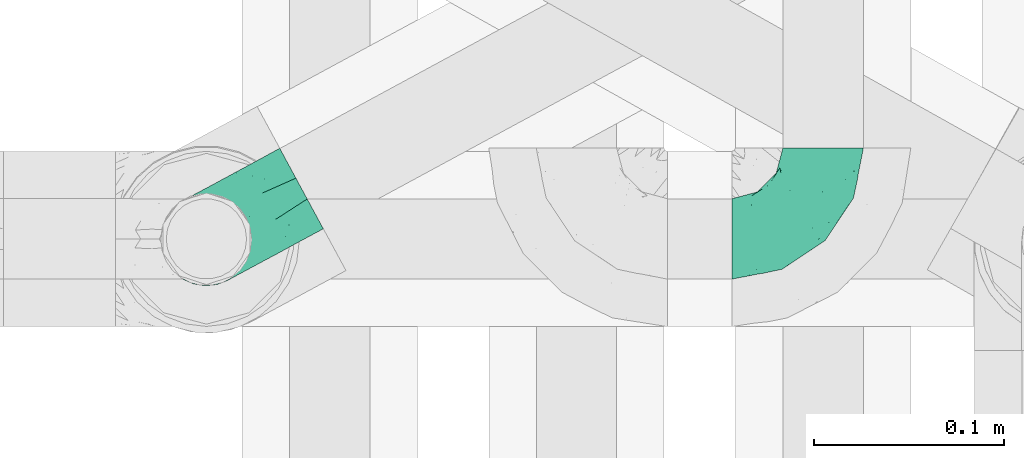
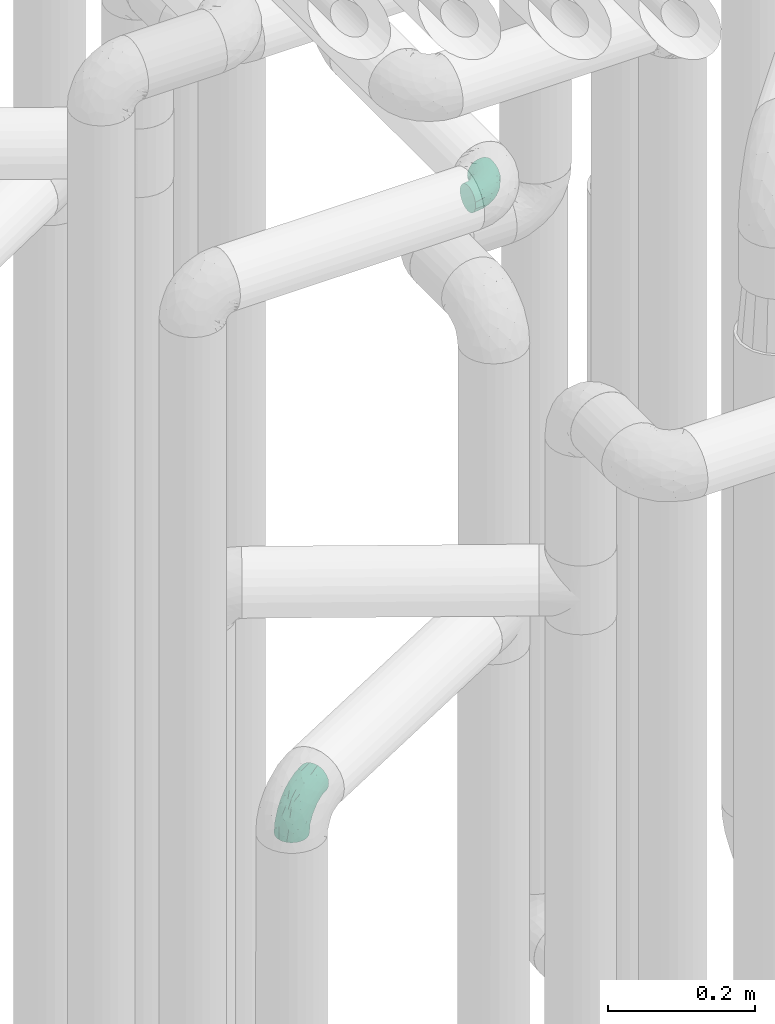
# One storey, part 793 of 827: 2 flow fittings.
"""IFC2X3 building model written with IfcOpenShell, lengths in millimetres."""

from ifc_helpers import new_model, entity, si_unit, converted_unit, derived_unit, direction, frame, origin, place, context, subcontext, project, spatial, faceted_brep, source, transform, mapped, material, type_object, type_shapes, element, save


model = new_model("IFC2X3")

# Units and contexts
model_context = context("Model", 3, precision=0.01, world=origin(), true_north=direction((6.12303176911189e-17, 1.0)))
body_context = subcontext(model_context, "Body", "Model", "MODEL_VIEW")
ifc_project = project(units=[si_unit("LENGTHUNIT", "METRE", prefix="MILLI"), si_unit("AREAUNIT", "SQUARE_METRE"), si_unit("VOLUMEUNIT", "CUBIC_METRE"), converted_unit("PLANEANGLEUNIT", "DEGREE", entity("IfcRatioMeasure", 0.0174532925199433), si_unit("PLANEANGLEUNIT", "RADIAN"), dimensions=[0, 0, 0, 0, 0, 0, 0]), si_unit("MASSUNIT", "GRAM", prefix="KILO"), derived_unit("MASSDENSITYUNIT", [(si_unit("MASSUNIT", "GRAM", prefix="KILO"), 1), (si_unit("LENGTHUNIT", "METRE"), -3)]), derived_unit("MOMENTOFINERTIAUNIT", [(si_unit("LENGTHUNIT", "METRE"), 4)]), si_unit("TIMEUNIT", "SECOND"), si_unit("FREQUENCYUNIT", "HERTZ"), si_unit("THERMODYNAMICTEMPERATUREUNIT", "DEGREE_CELSIUS"), derived_unit("THERMALTRANSMITTANCEUNIT", [(si_unit("MASSUNIT", "GRAM", prefix="KILO"), 1), (si_unit("THERMODYNAMICTEMPERATUREUNIT", "KELVIN"), -1), (si_unit("TIMEUNIT", "SECOND"), -3)]), derived_unit("VOLUMETRICFLOWRATEUNIT", [(si_unit("LENGTHUNIT", "METRE"), 3), (si_unit("TIMEUNIT", "SECOND"), -1)]), derived_unit("MASSFLOWRATEUNIT", [(si_unit("MASSUNIT", "GRAM", prefix="KILO"), 1), (si_unit("TIMEUNIT", "SECOND"), -1)]), derived_unit("ROTATIONALFREQUENCYUNIT", [(si_unit("TIMEUNIT", "SECOND"), -1)]), si_unit("ELECTRICCURRENTUNIT", "AMPERE"), si_unit("ELECTRICVOLTAGEUNIT", "VOLT"), si_unit("POWERUNIT", "WATT"), si_unit("FORCEUNIT", "NEWTON", prefix="KILO"), si_unit("ILLUMINANCEUNIT", "LUX"), si_unit("LUMINOUSFLUXUNIT", "LUMEN"), si_unit("LUMINOUSINTENSITYUNIT", "CANDELA"), derived_unit("USERDEFINED", [(si_unit("MASSUNIT", "GRAM", prefix="KILO"), -1), (si_unit("LENGTHUNIT", "METRE"), -2), (si_unit("TIMEUNIT", "SECOND"), 3), (si_unit("LUMINOUSFLUXUNIT", "LUMEN"), 1)]), derived_unit("LINEARVELOCITYUNIT", [(si_unit("LENGTHUNIT", "METRE"), 1), (si_unit("TIMEUNIT", "SECOND"), -1)]), si_unit("PRESSUREUNIT", "PASCAL"), derived_unit("USERDEFINED", [(si_unit("LENGTHUNIT", "METRE"), -2), (si_unit("MASSUNIT", "GRAM", prefix="KILO"), 1), (si_unit("TIMEUNIT", "SECOND"), -2)]), derived_unit("LINEARFORCEUNIT", [(si_unit("MASSUNIT", "GRAM", prefix="KILO"), 1), (si_unit("LENGTHUNIT", "METRE"), 1), (si_unit("TIMEUNIT", "SECOND"), -2), (si_unit("LENGTHUNIT", "METRE"), -1)]), derived_unit("PLANARFORCEUNIT", [(si_unit("MASSUNIT", "GRAM", prefix="KILO"), 1), (si_unit("LENGTHUNIT", "METRE"), 1), (si_unit("TIMEUNIT", "SECOND"), -2), (si_unit("LENGTHUNIT", "METRE"), -2)])], contexts=[model_context])

# Site, building, storey
site_placement = place(None, origin())
site = spatial("IfcSite", under=ifc_project, at=site_placement, CompositionType="ELEMENT")
building_placement = place(site_placement, origin())
building = spatial("IfcBuilding", under=site, at=building_placement, CompositionType="ELEMENT")
storey_placement = place(building_placement, frame((0.0, 0.0, 28200.0)))
storey = spatial("IfcBuildingStorey", under=building, at=storey_placement, Name="08", CompositionType="ELEMENT", Elevation=28200.0)

# Flow fittings
ifc_material = material()
pipe_fitting_type_1 = type_object("IfcPipeFittingType", Name="ADSK_1", PredefinedType="NOTDEFINED", material=ifc_material)
shared_shape_1 = source(origin(), body_context, "Body", "Brep", [
    faceted_brep([(-48.0, 10.6, -18.36), (-48.0, 5.49, -20.48), (-48.0, 0.0, -21.2), (-48.0, -5.49, -20.48), (-48.0, -10.6, -18.36), (-48.0, -14.99, -14.99), (-48.0, -18.36, -10.6), (-48.0, -20.48, -5.49), (-48.0, -21.2, 0.0), (-48.0, -20.48, 5.49), (-48.0, -18.36, 10.6), (-48.0, -14.99, 14.99), (-48.0, -10.6, 18.36), (-48.0, -5.49, 20.48), (-48.0, 0.0, 21.2), (-48.0, 5.49, 20.48), (-48.0, 10.6, 18.36), (-48.0, 14.99, 14.99), (-48.0, 18.36, 10.6), (-48.0, 20.48, 5.49), (-48.0, 21.2, 0.0), (-48.0, 20.48, -5.49), (-48.0, 18.36, -10.6), (-48.0, 14.99, -14.99), (0.0, 48.0, -21.2), (-5.49, 48.0, -20.48), (-10.6, 48.0, -18.36), (-14.99, 48.0, -14.99), (-18.36, 48.0, -10.6), (-20.48, 48.0, -5.49), (-21.2, 48.0, 0.0), (-20.48, 48.0, 5.49), (-18.36, 48.0, 10.6), (-14.99, 48.0, 14.99), (-10.6, 48.0, 18.36), (-5.49, 48.0, 20.48), (0.0, 48.0, 21.2), (5.48, 48.0, 20.48), (10.6, 48.0, 18.36), (14.99, 48.0, 14.99), (18.36, 48.0, 10.6), (20.48, 48.0, 5.49), (21.2, 48.0, 0.0), (20.48, 48.0, -5.49), (18.36, 48.0, -10.6), (14.99, 48.0, -14.99), (10.6, 48.0, -18.36), (5.48, 48.0, -20.48), (-35.26, -16.22, 12.01), (-34.76, -18.57, 0.0), (-20.87, -12.37, 10.9), (-31.49, -11.78, 15.9), (-37.01, -2.58, 20.86), (-33.89, 3.62, 21.15), (-31.81, -18.14, 6.76), (-5.78, 5.78, 17.67), (-19.42, -4.1, 17.86), (-9.6, -3.39, 13.73), (-35.45, -7.73, 19.13), (11.78, 31.49, 15.9), (-5.94, -5.46, 6.95), (-18.45, -13.78, 5.46), (-10.29, -8.43, 0.0), (-24.6, 0.55, 20.62), (-37.28, 17.94, 13.81), (-33.38, 22.85, 9.59), (-41.47, 20.06, 8.75), (-29.52, 20.45, 15.16), (-15.05, 10.79, 21.13), (-7.08, 16.98, 20.93), (-8.39, 23.51, 21.15), (-40.87, 13.03, 17.26), (-8.06, 41.27, 19.83), (-3.22, 35.97, 21.14), (8.53, 19.66, 14.74), (4.1, 19.42, 17.86), (-37.73, 22.66, 4.78), (-37.07, 8.58, 19.98), (-13.0, 5.43, 19.97), (-3.79, 13.93, 19.7), (3.02, 8.7, 13.43), (-2.27, -0.05, 10.65), (6.22, 7.0, 7.09), (-22.25, 34.61, 9.45), (18.14, 31.81, 6.76), (16.22, 35.26, 12.01), (12.37, 20.87, 10.9), (7.73, 35.45, 19.13), (-21.52, -15.93, 0.0), (2.58, 37.01, 20.86), (18.56, 34.76, 0.0), (13.78, 18.45, 5.46), (15.93, 21.52, 0.0), (-20.03, -8.54, 14.9), (-28.6, 28.6, 5.16), (-24.79, 34.6, 0.0), (-34.6, 24.79, 0.0), (-22.82, 37.41, 4.68), (-23.36, 26.33, 14.79), (-13.68, 37.05, 17.49), (-17.72, 38.13, 13.73), (-26.25, 27.3, 11.24), (-9.71, 32.34, 20.14), (-17.26, 25.6, 18.71), (-26.34, 9.99, 20.77), (-24.07, 6.05, 21.2), (-25.02, 15.46, 19.56), (-24.3, 20.72, 17.57), (-31.96, 15.23, 17.8), (-13.53, 24.7, 20.21), (-0.55, 24.6, 20.62), (-11.41, -7.48, 10.43), (-17.6, 17.6, 20.6), (0.93, -0.93, 0.0), (8.43, 10.3, 0.0), (-11.41, -7.48, -10.43), (-20.1, -8.84, -14.66), (-9.6, -3.39, -13.73), (7.73, 35.45, -19.13), (4.1, 19.42, -17.86), (-0.55, 24.6, -20.62), (-38.13, 17.72, -13.73), (-37.05, 13.68, -17.49), (-32.34, 9.71, -20.14), (-41.27, 8.05, -19.83), (-37.41, 22.81, -4.68), (-23.52, 8.39, -21.15), (-35.97, 3.21, -21.14), (-28.6, 28.6, -5.16), (-31.81, -18.14, -6.76), (-18.45, -13.78, -5.46), (-25.6, 17.26, -18.71), (-19.42, -4.1, -17.86), (-17.94, 37.28, -13.81), (-22.85, 33.38, -9.59), (-20.07, 41.46, -8.75), (-31.49, -11.78, -15.9), (-35.26, -16.22, -12.01), (8.53, 19.66, -14.74), (11.78, 31.49, -15.9), (-9.99, 26.34, -20.77), (-6.05, 24.06, -21.2), (-10.79, 15.04, -21.13), (-37.01, -2.58, -20.86), (-16.98, 7.08, -20.93), (-5.43, 13.0, -19.97), (-13.93, 3.79, -19.7), (-20.87, -12.37, -10.9), (-26.34, 23.36, -14.79), (-22.66, 37.72, -4.78), (13.78, 18.45, -5.46), (18.14, 31.81, -6.76), (-15.47, 25.02, -19.56), (-20.72, 24.3, -17.57), (16.22, 35.26, -12.01), (-13.03, 40.86, -17.26), (-8.58, 37.07, -19.98), (2.58, 37.01, -20.86), (-3.62, 33.89, -21.15), (-34.61, 22.25, -9.45), (6.22, 7.0, -7.09), (-20.45, 29.51, -15.16), (-35.45, -7.73, -19.13), (12.37, 20.87, -10.9), (-27.3, 26.25, -11.24), (-15.23, 31.95, -17.8), (-24.7, 13.53, -20.21), (-17.6, 17.6, -20.6), (-24.6, 0.55, -20.62), (-5.78, 5.78, -17.67), (3.02, 8.7, -13.43), (-5.94, -5.46, -6.95), (-2.27, -0.05, -10.65)], [[[0, 1, 2, 3, 4, 5, 6, 7, 8, 9, 10, 11, 12, 13, 14, 15, 16, 17, 18, 19, 20, 21, 22, 23]], [[24, 25, 26, 27, 28, 29, 30, 31, 32, 33, 34, 35, 36, 37, 38, 39, 40, 41, 42, 43, 44, 45, 46, 47]], [[10, 48, 11]], [[9, 8, 49]], [[48, 50, 51]], [[14, 52, 53]], [[10, 54, 48]], [[9, 54, 10]], [[55, 56, 57]], [[51, 12, 11]], [[51, 58, 12]], [[59, 39, 38]], [[60, 61, 62]], [[58, 56, 63]], [[64, 65, 66]], [[67, 65, 64]], [[68, 69, 70]], [[16, 71, 17]], [[13, 52, 14]], [[35, 72, 73]], [[14, 53, 15]], [[17, 64, 18]], [[74, 59, 75]], [[20, 19, 76]], [[66, 19, 18]], [[77, 15, 53]], [[15, 77, 16]], [[69, 78, 79]], [[80, 81, 82]], [[32, 31, 83]], [[84, 85, 86]], [[59, 87, 75]], [[61, 54, 88]], [[36, 89, 37]], [[84, 41, 40]], [[36, 35, 73]], [[90, 41, 84]], [[40, 39, 85]], [[12, 58, 13]], [[85, 84, 40]], [[91, 84, 86]], [[84, 92, 90]], [[87, 38, 37]], [[93, 56, 51]], [[65, 94, 76]], [[94, 95, 96]], [[84, 91, 92]], [[95, 97, 30]], [[98, 99, 100]], [[76, 94, 96]], [[101, 98, 83]], [[100, 99, 33]], [[102, 70, 73]], [[103, 102, 99]], [[94, 97, 95]], [[72, 99, 102]], [[72, 35, 34]], [[34, 33, 99]], [[9, 49, 54]], [[87, 59, 38]], [[104, 105, 68]], [[106, 103, 107]], [[106, 77, 104]], [[71, 64, 17]], [[108, 107, 67]], [[33, 32, 100]], [[102, 103, 109]], [[102, 109, 70]], [[89, 73, 110]], [[50, 48, 54]], [[51, 11, 48]], [[56, 58, 51]], [[88, 54, 49]], [[52, 58, 63]], [[50, 111, 93]], [[56, 55, 78]], [[39, 59, 85]], [[86, 85, 59]], [[89, 87, 37]], [[42, 41, 90]], [[110, 79, 75]], [[110, 75, 87]], [[75, 55, 80]], [[104, 77, 53]], [[71, 77, 108]], [[32, 83, 100]], [[98, 100, 83]], [[99, 98, 103]], [[106, 107, 108]], [[68, 70, 112]], [[110, 73, 70]], [[68, 112, 104]], [[68, 63, 78]], [[57, 93, 111]], [[80, 55, 57]], [[61, 50, 54]], [[80, 82, 86]], [[81, 57, 111]], [[74, 86, 59]], [[60, 113, 82]], [[82, 114, 91]], [[101, 94, 65]], [[97, 94, 83]], [[73, 89, 36]], [[87, 89, 110]], [[58, 52, 13]], [[53, 52, 63]], [[104, 53, 105]], [[106, 104, 112]], [[20, 76, 96]], [[76, 19, 66]], [[103, 106, 112]], [[77, 106, 108]], [[103, 98, 107]], [[67, 107, 98]], [[67, 98, 101]], [[108, 67, 64]], [[53, 63, 105]], [[63, 68, 105]], [[83, 31, 97]], [[30, 97, 31]], [[62, 113, 60]], [[111, 61, 60]], [[61, 88, 62]], [[86, 82, 91]], [[56, 78, 63]], [[114, 82, 113]], [[114, 92, 91]], [[79, 78, 55]], [[75, 79, 55]], [[69, 79, 110]], [[70, 69, 110]], [[78, 69, 68]], [[77, 71, 16]], [[64, 71, 108]], [[64, 66, 18]], [[76, 66, 65]], [[99, 72, 34]], [[73, 72, 102]], [[94, 101, 83]], [[67, 101, 65]], [[75, 80, 74]], [[80, 86, 74]], [[103, 112, 109]], [[70, 109, 112]], [[50, 93, 51]], [[57, 56, 93]], [[61, 111, 50]], [[81, 111, 60]], [[82, 81, 60]], [[80, 57, 81]], [[115, 116, 117]], [[118, 119, 120]], [[121, 122, 23]], [[123, 124, 122]], [[96, 125, 20]], [[123, 126, 127]], [[128, 96, 95]], [[129, 130, 88]], [[123, 122, 131]], [[116, 132, 117]], [[133, 134, 135]], [[0, 124, 1]], [[5, 136, 137]], [[138, 119, 139]], [[129, 88, 49]], [[140, 141, 142]], [[6, 5, 137]], [[46, 118, 47]], [[143, 3, 2]], [[144, 145, 146]], [[6, 129, 7]], [[129, 137, 147]], [[127, 2, 1]], [[148, 122, 121]], [[128, 125, 96]], [[134, 128, 149]], [[95, 149, 128]], [[150, 151, 92]], [[30, 29, 149]], [[152, 131, 153]], [[27, 133, 28]], [[154, 45, 44]], [[136, 5, 4]], [[27, 26, 155]], [[156, 26, 25]], [[24, 157, 158]], [[24, 47, 157]], [[22, 21, 159]], [[160, 150, 114]], [[134, 133, 161]], [[142, 144, 126]], [[46, 139, 118]], [[162, 136, 4]], [[156, 25, 158]], [[1, 124, 127]], [[115, 147, 116]], [[45, 154, 139]], [[139, 46, 45]], [[154, 163, 139]], [[162, 4, 3]], [[42, 90, 43]], [[130, 129, 147]], [[49, 7, 129]], [[43, 151, 44]], [[0, 23, 122]], [[24, 158, 25]], [[136, 162, 132]], [[135, 29, 28]], [[43, 90, 151]], [[164, 148, 159]], [[152, 156, 140]], [[155, 133, 27]], [[165, 153, 161]], [[23, 22, 121]], [[166, 131, 167]], [[123, 166, 126]], [[143, 127, 168]], [[147, 137, 136]], [[8, 7, 49]], [[129, 6, 137]], [[143, 162, 3]], [[168, 146, 132]], [[168, 132, 162]], [[132, 169, 117]], [[44, 151, 154]], [[92, 151, 90]], [[163, 154, 151]], [[119, 118, 139]], [[157, 118, 120]], [[138, 139, 163]], [[119, 169, 145]], [[140, 156, 158]], [[155, 156, 165]], [[22, 159, 121]], [[148, 121, 159]], [[122, 148, 131]], [[152, 153, 165]], [[142, 126, 167]], [[168, 127, 126]], [[142, 167, 140]], [[142, 120, 145]], [[169, 170, 117]], [[160, 171, 172]], [[115, 172, 171]], [[171, 62, 130]], [[119, 170, 169]], [[170, 163, 160]], [[150, 163, 151]], [[113, 171, 160]], [[164, 128, 134]], [[125, 128, 159]], [[127, 143, 2]], [[162, 143, 168]], [[118, 157, 47]], [[158, 157, 120]], [[140, 158, 141]], [[152, 140, 167]], [[30, 149, 95]], [[149, 29, 135]], [[131, 152, 167]], [[156, 152, 165]], [[131, 148, 153]], [[161, 153, 148]], [[161, 148, 164]], [[165, 161, 133]], [[158, 120, 141]], [[120, 142, 141]], [[159, 21, 125]], [[20, 125, 21]], [[115, 130, 147]], [[114, 113, 160]], [[62, 171, 113]], [[62, 88, 130]], [[160, 163, 150]], [[150, 92, 114]], [[119, 145, 120]], [[146, 145, 169]], [[132, 146, 169]], [[144, 146, 168]], [[126, 144, 168]], [[145, 144, 142]], [[156, 155, 26]], [[133, 155, 165]], [[133, 135, 28]], [[149, 135, 134]], [[122, 124, 0]], [[127, 124, 123]], [[128, 164, 159]], [[161, 164, 134]], [[163, 170, 138]], [[170, 119, 138]], [[126, 166, 167]], [[123, 131, 166]], [[147, 136, 116]], [[132, 116, 136]], [[172, 115, 117]], [[130, 115, 171]], [[117, 170, 172]], [[160, 172, 170]]]),
])
type_shapes(pipe_fitting_type_1, [shared_shape_1])
flow_fitting_1_placement = place(storey_placement, frame((35600.09, 11556.18, 3000.0)))
element("IfcFlowFitting", 1, at=flow_fitting_1_placement, inside=storey, type_object=pipe_fitting_type_1, material=ifc_material, Name="ADSK_1", ObjectType="ADSK_1", context=body_context, shape_type="MappedRepresentation", body=[
    mapped(shared_shape_1, transform((0.0, 0.0, 0.0), scale=1.0)),
])
pipe_fitting_type_2 = type_object("IfcPipeFittingType", Name="ADSK_1", PredefinedType="NOTDEFINED", material=ifc_material)
shared_shape_2 = source(origin(), body_context, "Body", "Brep", [
    faceted_brep([(-57.03, 12.07, -20.91), (-57.03, 6.25, -23.33), (-57.03, 0.0, -24.15), (-57.03, -6.25, -23.33), (-57.03, -12.08, -20.91), (-57.03, -17.08, -17.08), (-57.03, -20.91, -12.08), (-57.03, -23.33, -6.25), (-57.03, -24.15, 0.0), (-57.03, -23.33, 6.25), (-57.03, -20.91, 12.07), (-57.03, -17.08, 17.08), (-57.03, -12.08, 20.91), (-57.03, -6.25, 23.33), (-57.03, 0.0, 24.15), (-57.03, 6.25, 23.33), (-57.03, 12.07, 20.91), (-57.03, 17.08, 17.08), (-57.03, 20.91, 12.07), (-57.03, 23.33, 6.25), (-57.03, 24.15, 0.0), (-57.03, 23.33, -6.25), (-57.03, 20.91, -12.08), (-57.03, 17.08, -17.08), (-0.03, 57.03, -24.15), (-6.28, 57.02, -23.33), (-12.1, 57.02, -20.91), (-17.1, 57.02, -17.08), (-20.94, 57.02, -12.08), (-23.35, 57.02, -6.25), (-24.18, 57.02, 0.0), (-23.35, 57.02, 6.25), (-20.94, 57.02, 12.07), (-17.1, 57.02, 17.08), (-12.1, 57.02, 20.91), (-6.28, 57.02, 23.33), (-0.03, 57.03, 24.15), (6.22, 57.03, 23.33), (12.05, 57.03, 20.91), (17.05, 57.03, 17.08), (20.89, 57.04, 12.07), (23.3, 57.04, 6.25), (24.12, 57.04, 0.0), (23.3, 57.04, -6.25), (20.89, 57.04, -12.08), (17.05, 57.03, -17.08), (12.05, 57.03, -20.91), (6.22, 57.03, -23.33), (14.9, 21.18, 6.17), (13.6, 24.68, 12.48), (6.23, 8.96, 8.96), (-41.49, -21.06, 0.0), (-41.94, -18.38, 13.72), (-24.67, -13.62, 12.48), (-37.4, -13.24, 18.15), (-6.83, -4.94, 8.18), (-21.79, -15.2, 6.22), (-12.8, -9.17, 0.0), (-37.75, -20.51, 7.75), (-7.4, 7.39, 20.24), (-23.39, -4.26, 20.42), (-11.92, -3.19, 15.85), (-42.17, -8.7, 21.82), (13.22, 37.4, 18.15), (9.31, 23.55, 16.86), (4.25, 23.39, 20.42), (2.76, 10.93, 15.55), (-29.48, 0.91, 23.52), (-44.16, 20.56, 15.69), (-39.27, 26.33, 10.88), (-49.05, 22.92, 9.96), (-34.6, 23.88, 17.15), (-15.82, 6.8, 22.81), (-8.69, 20.49, 23.88), (-18.14, 12.91, 24.08), (-48.31, 14.93, 19.66), (-44.08, -2.85, 23.78), (-9.25, 48.97, 22.58), (-3.8, 42.76, 24.07), (-40.36, 4.26, 24.09), (-44.04, 26.14, 5.46), (-44.06, 9.88, 22.74), (-4.97, 16.88, 22.52), (-2.77, 1.43, 12.5), (-25.5, 40.99, 10.71), (20.49, 37.76, 7.75), (18.36, 41.95, 13.72), (8.68, 42.18, 21.82), (-25.96, -17.97, 0.0), (2.83, 44.08, 23.78), (21.04, 41.5, 0.0), (17.96, 25.97, 0.0), (-24.06, -9.27, 17.13), (-33.28, 33.27, 5.86), (-28.57, 40.58, 0.0), (-40.6, 28.55, 0.0), (-25.31, 47.2, 4.06), (-27.03, 31.11, 16.77), (-15.72, 43.97, 19.9), (-20.29, 45.24, 15.61), (-30.55, 31.99, 12.64), (-11.3, 38.35, 22.92), (-9.98, 27.89, 24.09), (-20.17, 30.27, 21.25), (-31.27, 11.75, 23.64), (-28.77, 7.24, 24.15), (-29.54, 18.07, 22.27), (-28.46, 24.21, 20.02), (-37.57, 17.7, 20.26), (-15.9, 29.26, 22.99), (-20.84, 20.83, 23.44), (-0.93, 29.47, 23.52), (-13.53, -7.67, 12.04), (1.46, 1.55, 5.16), (8.81, 10.31, 4.57), (0.37, -0.37, 0.0), (9.16, 12.8, 0.0), (-37.4, -13.24, -18.15), (8.81, 10.31, -4.57), (-45.25, 20.27, -15.61), (-43.98, 15.7, -19.9), (-38.35, 11.28, -22.92), (-48.97, 9.23, -22.58), (-47.21, 25.29, -4.06), (-33.28, 33.27, -5.86), (18.36, 41.95, -13.72), (-30.28, 20.16, -21.25), (2.83, 44.08, -23.78), (-4.28, 40.36, -24.09), (-41.0, 25.48, -10.71), (-41.94, -18.38, -13.72), (9.23, 23.53, -16.92), (4.25, 23.39, -20.42), (13.22, 37.4, -18.15), (-37.75, -20.51, -7.75), (-11.76, 31.26, -23.64), (-7.25, 28.77, -24.15), (-12.91, 18.13, -24.08), (8.68, 42.18, -21.82), (-44.08, -2.85, -23.78), (-6.81, 15.82, -22.81), (-20.49, 8.68, -23.88), (-24.67, -13.62, -12.48), (-42.76, 3.78, -24.07), (-18.08, 29.54, -22.27), (-24.23, 28.45, -20.02), (-27.9, 9.97, -24.09), (-31.12, 27.02, -16.77), (-26.17, 44.03, -5.46), (14.9, 21.18, -6.17), (20.49, 37.76, -7.75), (-9.9, 44.06, -22.74), (-20.58, 44.15, -15.69), (-21.79, -15.2, -6.22), (-13.53, -7.67, -12.04), (-24.16, -9.75, -16.74), (-11.92, -3.19, -15.85), (-14.95, 48.3, -19.66), (-23.39, -4.26, -20.42), (-0.93, 29.47, -23.52), (-26.35, 39.26, -10.88), (-23.89, 34.59, -17.15), (-42.17, -8.7, -21.82), (-22.95, 49.04, -9.96), (13.6, 24.68, -12.48), (-32.01, 30.53, -12.64), (-16.88, 4.96, -22.52), (-17.72, 37.56, -20.26), (-29.26, 15.89, -22.99), (-20.84, 20.83, -23.44), (-29.48, 0.91, -23.52), (-7.4, 7.39, -20.24), (2.76, 10.93, -15.55), (6.23, 8.96, -8.96), (-6.83, -4.94, -8.18), (-2.82, 1.41, -12.53), (1.46, 1.55, -5.16)], [[[0, 1, 2, 3, 4, 5, 6, 7, 8, 9, 10, 11, 12, 13, 14, 15, 16, 17, 18, 19, 20, 21, 22, 23]], [[24, 25, 26, 27, 28, 29, 30, 31, 32, 33, 34, 35, 36, 37, 38, 39, 40, 41, 42, 43, 44, 45, 46, 47]], [[48, 49, 50]], [[9, 8, 51]], [[52, 53, 54]], [[55, 56, 57]], [[10, 58, 52]], [[9, 58, 10]], [[59, 60, 61]], [[54, 12, 11]], [[54, 62, 12]], [[63, 39, 38]], [[64, 65, 66]], [[62, 60, 67]], [[68, 69, 70]], [[71, 69, 68]], [[72, 73, 74]], [[16, 75, 17]], [[13, 76, 14]], [[35, 77, 78]], [[14, 79, 15]], [[17, 68, 18]], [[14, 76, 79]], [[20, 19, 80]], [[70, 19, 18]], [[81, 15, 79]], [[15, 81, 16]], [[73, 72, 82]], [[66, 83, 50]], [[32, 31, 84]], [[85, 86, 49]], [[63, 87, 65]], [[56, 58, 88]], [[36, 89, 37]], [[85, 41, 40]], [[36, 35, 78]], [[90, 41, 85]], [[40, 39, 86]], [[12, 62, 13]], [[86, 85, 40]], [[48, 85, 49]], [[85, 91, 90]], [[87, 38, 37]], [[92, 60, 54]], [[80, 69, 93]], [[93, 94, 95]], [[10, 52, 11]], [[94, 96, 30]], [[97, 98, 99]], [[80, 93, 95]], [[100, 97, 84]], [[99, 98, 33]], [[101, 102, 78]], [[103, 101, 98]], [[96, 31, 30]], [[77, 98, 101]], [[77, 35, 34]], [[34, 33, 98]], [[9, 51, 58]], [[87, 63, 38]], [[104, 105, 74]], [[106, 103, 107]], [[106, 81, 104]], [[75, 68, 17]], [[108, 107, 71]], [[33, 32, 99]], [[109, 103, 110]], [[101, 109, 102]], [[89, 78, 111]], [[53, 52, 58]], [[54, 11, 52]], [[60, 62, 54]], [[88, 58, 51]], [[76, 62, 67]], [[53, 112, 92]], [[60, 59, 72]], [[39, 63, 86]], [[49, 86, 63]], [[89, 87, 37]], [[42, 41, 90]], [[111, 82, 65]], [[111, 65, 87]], [[65, 59, 66]], [[104, 81, 79]], [[75, 81, 108]], [[32, 84, 99]], [[97, 99, 84]], [[98, 97, 103]], [[106, 107, 108]], [[74, 102, 110]], [[111, 78, 102]], [[74, 110, 104]], [[74, 67, 72]], [[61, 92, 112]], [[66, 59, 61]], [[56, 53, 58]], [[66, 50, 49]], [[61, 112, 83]], [[66, 49, 64]], [[78, 89, 36]], [[87, 89, 111]], [[62, 76, 13]], [[79, 76, 67]], [[100, 93, 69]], [[96, 93, 84]], [[55, 113, 50]], [[113, 114, 50]], [[104, 79, 105]], [[106, 104, 110]], [[20, 80, 95]], [[85, 48, 91]], [[115, 114, 113]], [[116, 91, 48]], [[70, 80, 19]], [[93, 96, 94]], [[84, 31, 96]], [[79, 67, 105]], [[67, 74, 105]], [[103, 106, 110]], [[81, 106, 108]], [[103, 97, 107]], [[71, 107, 97]], [[71, 97, 100]], [[108, 71, 68]], [[115, 113, 57]], [[112, 56, 55]], [[56, 88, 57]], [[60, 72, 67]], [[82, 72, 59]], [[65, 82, 59]], [[82, 111, 73]], [[111, 102, 73]], [[102, 74, 73]], [[81, 75, 16]], [[68, 75, 108]], [[68, 70, 18]], [[80, 70, 69]], [[98, 77, 34]], [[78, 77, 101]], [[93, 100, 84]], [[71, 100, 69]], [[102, 109, 110]], [[101, 103, 109]], [[53, 92, 54]], [[61, 60, 92]], [[56, 112, 53]], [[83, 112, 55]], [[50, 83, 55]], [[61, 83, 66]], [[49, 63, 64]], [[65, 64, 63]], [[57, 113, 55]], [[114, 115, 116]], [[116, 48, 114]], [[48, 50, 114]], [[117, 5, 4]], [[116, 115, 118]], [[119, 120, 23]], [[121, 122, 120]], [[95, 123, 20]], [[0, 23, 120]], [[124, 95, 94]], [[125, 45, 44]], [[121, 120, 126]], [[24, 127, 128]], [[22, 21, 129]], [[0, 122, 1]], [[5, 117, 130]], [[131, 132, 133]], [[134, 88, 51]], [[135, 136, 137]], [[6, 5, 130]], [[46, 138, 47]], [[139, 3, 2]], [[140, 141, 137]], [[6, 134, 7]], [[134, 130, 142]], [[143, 2, 1]], [[144, 126, 145]], [[121, 146, 143]], [[147, 120, 119]], [[94, 148, 124]], [[149, 150, 91]], [[30, 29, 148]], [[151, 25, 128]], [[27, 152, 28]], [[134, 153, 88]], [[154, 155, 156]], [[27, 26, 157]], [[151, 26, 25]], [[155, 158, 156]], [[24, 47, 127]], [[1, 122, 143]], [[138, 132, 159]], [[160, 152, 161]], [[24, 128, 25]], [[46, 133, 138]], [[162, 117, 4]], [[148, 160, 124]], [[152, 160, 163]], [[154, 142, 155]], [[45, 125, 133]], [[133, 46, 45]], [[125, 164, 133]], [[51, 7, 134]], [[42, 90, 43]], [[165, 147, 129]], [[153, 134, 142]], [[43, 150, 44]], [[162, 4, 3]], [[141, 140, 166]], [[117, 162, 158]], [[163, 29, 28]], [[43, 90, 150]], [[123, 21, 20]], [[144, 151, 135]], [[157, 152, 27]], [[167, 145, 161]], [[23, 22, 119]], [[168, 126, 169]], [[121, 168, 146]], [[139, 143, 170]], [[142, 130, 117]], [[8, 7, 51]], [[134, 6, 130]], [[139, 162, 3]], [[170, 166, 158]], [[170, 158, 162]], [[158, 171, 156]], [[44, 150, 125]], [[91, 150, 90]], [[164, 125, 150]], [[132, 138, 133]], [[127, 138, 159]], [[131, 164, 172]], [[132, 171, 140]], [[135, 151, 128]], [[157, 151, 167]], [[22, 129, 119]], [[147, 119, 129]], [[120, 147, 126]], [[144, 145, 167]], [[137, 146, 169]], [[170, 143, 146]], [[137, 169, 135]], [[137, 159, 140]], [[171, 172, 156]], [[173, 174, 175]], [[156, 175, 154]], [[174, 57, 153]], [[132, 172, 171]], [[172, 164, 173]], [[143, 139, 2]], [[162, 139, 170]], [[138, 127, 47]], [[128, 127, 159]], [[165, 124, 160]], [[123, 124, 129]], [[149, 173, 164]], [[176, 174, 173]], [[135, 128, 136]], [[144, 135, 169]], [[150, 149, 164]], [[176, 118, 115]], [[149, 91, 116]], [[30, 148, 94]], [[163, 148, 29]], [[124, 123, 95]], [[129, 21, 123]], [[128, 159, 136]], [[159, 137, 136]], [[126, 144, 169]], [[151, 144, 167]], [[126, 147, 145]], [[161, 145, 147]], [[161, 147, 165]], [[167, 161, 152]], [[154, 153, 142]], [[132, 140, 159]], [[174, 176, 57]], [[57, 88, 153]], [[166, 140, 171]], [[158, 166, 171]], [[166, 170, 141]], [[170, 146, 141]], [[146, 137, 141]], [[151, 157, 26]], [[152, 157, 167]], [[152, 163, 28]], [[148, 163, 160]], [[120, 122, 0]], [[143, 122, 121]], [[124, 165, 129]], [[161, 165, 160]], [[146, 168, 169]], [[121, 126, 168]], [[142, 117, 155]], [[158, 155, 117]], [[175, 156, 172]], [[153, 154, 174]], [[173, 175, 172]], [[174, 154, 175]], [[164, 131, 133]], [[172, 132, 131]], [[176, 173, 118]], [[57, 176, 115]], [[173, 149, 118]], [[149, 116, 118]]]),
])
type_shapes(pipe_fitting_type_2, [shared_shape_2])
flow_fitting_2_placement = place(storey_placement, frame((35275.03, 11555.59, 2100.0), z_axis=(0.476176074774438, -0.879349535467556, -0.000860398397797428), x_axis=(-0.879349860952549, -0.476176251027635, 0.0)))
element("IfcFlowFitting", 2, at=flow_fitting_2_placement, inside=storey, type_object=pipe_fitting_type_2, material=ifc_material, Name="ADSK_1", ObjectType="ADSK_1", context=body_context, shape_type="MappedRepresentation", body=[
    mapped(shared_shape_2, transform((0.0, 0.0, 0.0), scale=1.0)),
])

save(model, "model.ifc")
